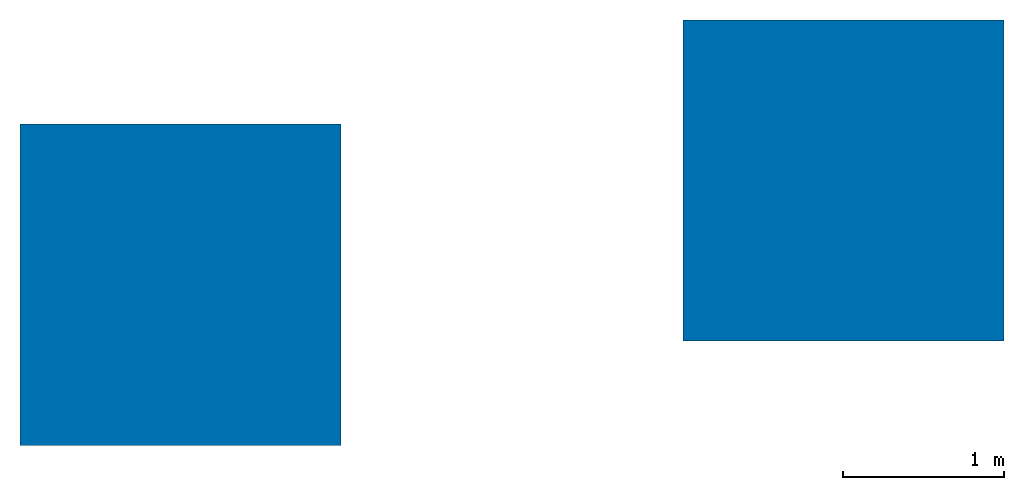
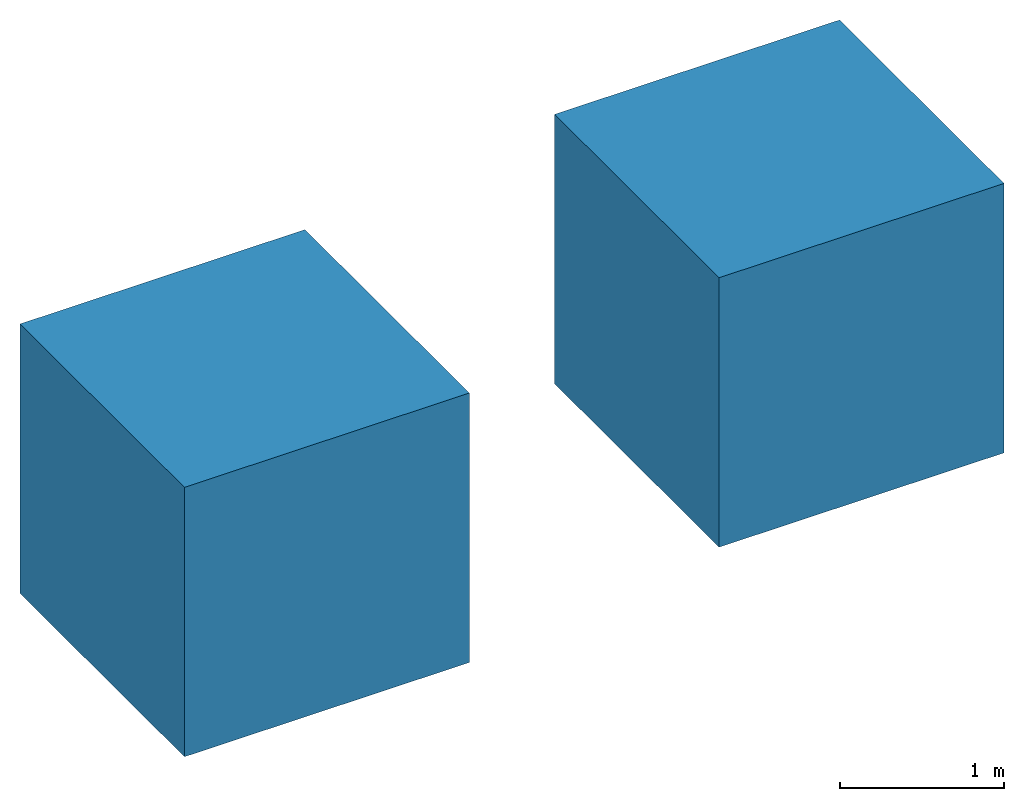
# One storey: 2 walls.
"""IFC4 building model written with IfcOpenShell, lengths in metres."""

from ifc_helpers import new_model, entity, si_unit, converted_unit, frame, frame_2d, origin_with_axes, place, context, subcontext, project, spatial, polygons, element, save


model = new_model("IFC4")

# Units and contexts
model_context = context("Model", 3, precision=1e-05, world=origin_with_axes())
plan_context = context("Plan", 2, precision=1e-05, world=frame_2d((0.0, 0.0, 0.0), x_axis=(1.0, 0.0, 0.0)))
body_context = subcontext(model_context, "Body", "Model", "MODEL_VIEW")
ifc_project = project(units=[si_unit("VOLUMEUNIT", "CUBIC_METRE"), si_unit("LENGTHUNIT", "METRE"), converted_unit("PLANEANGLEUNIT", "degree", entity("IfcReal", 0.0174532925199433), si_unit("PLANEANGLEUNIT", "RADIAN"), dimensions=[0, 0, 0, 0, 0, 0, 0]), si_unit("AREAUNIT", "SQUARE_METRE")], contexts=[model_context, plan_context])

# Site, building, storey
site_placement = place(None, origin_with_axes())
site = spatial("IfcSite", under=ifc_project, at=site_placement)
building_placement = place(site_placement, origin_with_axes())
building = spatial("IfcBuilding", under=site, at=building_placement, Name="Building")
storey_placement = place(building_placement, origin_with_axes())
storey = spatial("IfcBuildingStorey", under=building, at=storey_placement, Name="Storey")

# Walls
for number, where, z_axis, x_axis, name in (
    (1, (0.0, 0.0, 0.0), (0.0, 0.0, 1.0), (1.0, 0.0, 0.0), "Cube"),
    (2, (4.12777042388916, 0.648530066013336, -0.282612591981888), (0.0, 0.0, 1.0), (1.0, 0.0, 0.0), "Cube"),
):
    element("IfcWall", number, at=place(storey_placement, frame(where, z_axis=z_axis, x_axis=x_axis)), inside=storey, Name=name, PredefinedType="SOLIDWALL", context=body_context, shape_type="Tessellation", body=[
        polygons([(1.0, 1.0, 1.0), (1.0, 1.0, -1.0), (1.0, -1.0, 1.0), (1.0, -1.0, -1.0), (-1.0, 1.0, 1.0), (-1.0, 1.0, -1.0), (-1.0, -1.0, 1.0), (-1.0, -1.0, -1.0)], [[[1, 5, 7, 3]], [[4, 3, 7, 8]], [[8, 7, 5, 6]], [[6, 2, 4, 8]], [[2, 1, 3, 4]], [[6, 5, 1, 2]]]),
    ])

save(model, "model.ifc")
